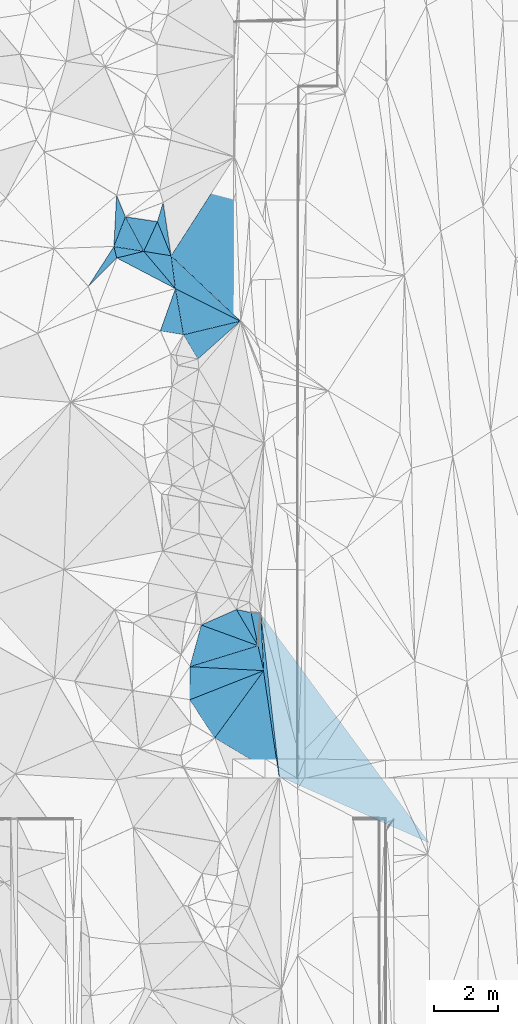
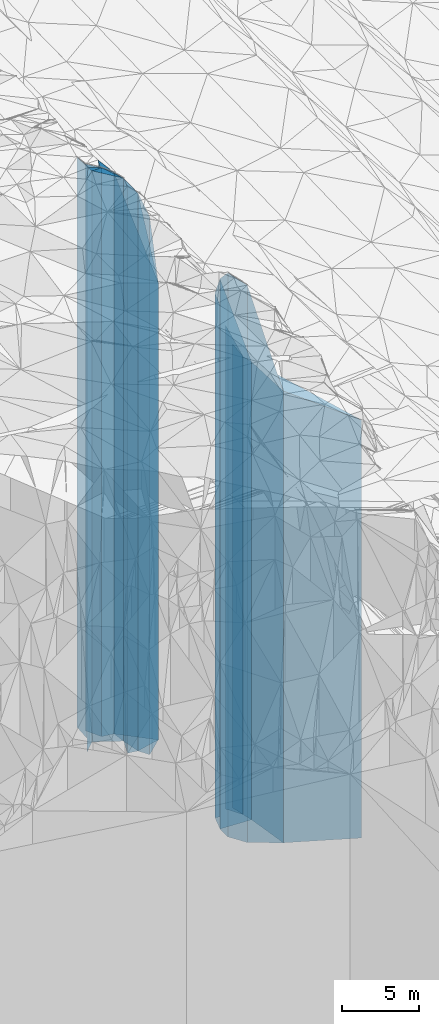
# One storey, part 250 of 275: 25 plates.
"""IFC2X3 building model written with IfcOpenShell, lengths in millimetres."""

from ifc_helpers import new_model, si_unit, frame, origin_with_axes, place, context, subcontext, project, spatial, faceted_brep, material, type_object, element, save


model = new_model("IFC2X3")

# Units and contexts
model_context = context("Model", 3, precision=1e-05, world=origin_with_axes())
body_context = subcontext(model_context, "Body", "Model", "MODEL_VIEW")
ifc_project = project(units=[si_unit("LENGTHUNIT", "METRE", prefix="MILLI"), si_unit("AREAUNIT", "SQUARE_METRE"), si_unit("VOLUMEUNIT", "CUBIC_METRE"), si_unit("MASSUNIT", "GRAM", prefix="KILO"), si_unit("TIMEUNIT", "SECOND"), si_unit("PLANEANGLEUNIT", "RADIAN"), si_unit("SOLIDANGLEUNIT", "STERADIAN"), si_unit("THERMODYNAMICTEMPERATUREUNIT", "DEGREE_CELSIUS"), si_unit("LUMINOUSINTENSITYUNIT", "LUMEN")], contexts=[model_context])

# Site, building, storey
site_placement = place(None, origin_with_axes())
site = spatial("IfcSite", under=ifc_project, at=site_placement, CompositionType="ELEMENT")
building_placement = place(site_placement, origin_with_axes())
building = spatial("IfcBuilding", under=site, at=building_placement, Name="Undefined", CompositionType="ELEMENT")
storey_placement = place(building_placement, origin_with_axes())
storey = spatial("IfcBuildingStorey", under=building, at=storey_placement, Name="Undefined", CompositionType="ELEMENT", Elevation=0.0)

# Plates
ifc_material = material()
plate_type_1 = type_object("IfcPlateType", PredefinedType="NOTDEFINED")
plate_1_placement = place(storey_placement, frame((-98025.9902817221, 87149.6399205856, 24399.5), z_axis=(0.993619641159463, 0.112783016018102, 0.0), x_axis=(0.1127830160181, -0.993619641159464, 0.0)))
element("IfcPlate", 1, at=plate_1_placement, inside=storey, type_object=plate_type_1, material=ifc_material, Name="00", context=body_context, shape_type="Brep", body=[
    faceted_brep([(0.0, -19435.4938964844, 1.09139364212751e-11), (7664.63574218751, -16571.5, 4398.71533203125), (7664.63574218751, 16571.5, 4398.71533203125), (0.0, 16571.5, -1.45519152283669e-11), (5089.28759765624, -19242.4938964844, -2.58587533608079e-08), (5089.28759765624, 16571.5, -2.58587533608079e-08)], [[[0, 1, 2, 3]], [[1, 4, 5, 2]], [[4, 0, 3, 5]], [[5, 3, 2]], [[4, 1, 0]]]),
])
plate_type_2 = type_object("IfcPlateType", PredefinedType="NOTDEFINED")
plate_2_placement = place(storey_placement, frame((-99455.0462103088, 83284.5981157701, 25979.0), z_axis=(-0.808835813129093, 0.588034546093849, 0.0), x_axis=(0.58803454609385, 0.808835813129092, 0.0)))
element("IfcPlate", 2, at=plate_2_placement, inside=storey, type_object=plate_type_2, material=ifc_material, Name="00", context=body_context, shape_type="Brep", body=[
    faceted_brep([(1.81898940354586e-12, -26031.0, 0.0), (503.80255126954, -26561.0, 1326.30419921874), (503.80255126954, 18151.0, 1326.30419921874), (1.81898940354586e-12, 18151.0, 0.0), (2589.90356445314, -18151.0, 9.29867383092642e-09), (2589.90356445314, 18151.0, 9.29867383092642e-09)], [[[0, 1, 2, 3]], [[1, 4, 5, 2]], [[4, 0, 3, 5]], [[5, 3, 2]], [[4, 1, 0]]]),
])
plate_type_3 = type_object("IfcPlateType", PredefinedType="NOTDEFINED")
plate_3_placement = place(storey_placement, frame((-97932.0934962247, 85379.4047967466, 25979.0), z_axis=(-0.053140453992429, -0.998587047857861, 0.0), x_axis=(-0.998587047857861, 0.0531404539924359, 0.0)))
element("IfcPlate", 3, at=plate_3_placement, inside=storey, type_object=plate_type_3, material=ifc_material, Name="00", context=body_context, shape_type="Brep", body=[
    faceted_brep([(0.0, -18151.0, -1.45519152283669e-11), (2247.99316406251, -26561.0, 1028.31274414061), (2247.99316406251, 18151.0, 1028.31274414061), (1.81898940354586e-12, 18151.0, 0.0), (2298.71704101564, -25471.0, -4.72937244921923e-09), (2298.71704101564, 18151.0, -4.72937244921923e-09)], [[[0, 1, 2, 3]], [[1, 4, 5, 2]], [[4, 0, 3, 5]], [[5, 3, 2]], [[4, 1, 0]]]),
])
plate_type_4 = type_object("IfcPlateType", PredefinedType="NOTDEFINED")
plate_4_placement = place(storey_placement, frame((-97932.0934962247, 85379.4047967466, 25831.5), z_axis=(-0.998596235263294, -0.0529675270139661, 0.0), x_axis=(-0.0529675270139622, 0.998596235263295, 0.0)))
element("IfcPlate", 4, at=plate_4_placement, inside=storey, type_object=plate_type_4, material=ifc_material, Name="00", context=body_context, shape_type="Brep", body=[
    faceted_brep([(0.0, -18298.5, 1.45519152283669e-11), (782.389282226563, -18318.5, 136.992584228516), (782.389282226563, 18003.5, 136.992584228516), (0.0, 18003.5, 1.45519152283669e-11), (1772.7236328125, -18003.5, 4.51109372079372e-10), (1772.7236328125, 18003.5, 4.51109372079372e-10)], [[[0, 1, 2, 3]], [[1, 4, 5, 2]], [[4, 0, 3, 5]], [[5, 3, 2]], [[4, 1, 0]]]),
])
plate_type_5 = type_object("IfcPlateType", PredefinedType="NOTDEFINED")
plate_5_placement = place(storey_placement, frame((-99455.0462103088, 83284.5981157701, 25735.0), z_axis=(0.511321646953997, 0.859389418922674, 0.0), x_axis=(0.859389418922677, -0.511321646953993, 0.0)))
element("IfcPlate", 5, at=plate_5_placement, inside=storey, type_object=plate_type_5, material=ifc_material, Name="00", context=body_context, shape_type="Brep", body=[
    faceted_brep([(2.91038304567337e-11, -26275.0, 7.27595761418343e-12), (237.689437866211, -18395.0, 2578.97338867188), (237.689437866211, 17907.0, 2578.97338867188), (7.27595761418343e-12, 17907.0, 1.45519152283669e-11), (2330.77246093753, -17907.0, -7.38509697839618e-09), (2330.77246093753, 17907.0, -7.38509697839618e-09)], [[[0, 1, 2, 3]], [[1, 4, 5, 2]], [[4, 0, 3, 5]], [[5, 3, 2]], [[4, 1, 0]]]),
])
plate_type_6 = type_object("IfcPlateType", PredefinedType="NOTDEFINED")
plate_6_placement = place(storey_placement, frame((-98782.3835816159, 87277.6952831278, 25989.0), z_axis=(0.404396271985505, -0.914583869967225, 0.0), x_axis=(-0.914583869967225, -0.404396271985505, 0.0)))
element("IfcPlate", 6, at=plate_6_placement, inside=storey, type_object=plate_type_6, material=ifc_material, Name="00", context=body_context, shape_type="Brep", body=[
    faceted_brep([(0.0, -20191.0, -1.45519152283669e-11), (-160.000000000022, -18161.0, 1299.99999999999), (-160.000000000022, 18161.0, 1299.99999999999), (0.0, 18161.0, -1.45519152283669e-11), (1189.99999999999, -23411.0, -6.97036739438772e-09), (1189.99999999999, 18161.0, -6.97036739438772e-09)], [[[0, 1, 2, 3]], [[1, 4, 5, 2]], [[4, 0, 3, 5]], [[5, 3, 2]], [[4, 1, 0]]]),
])
plate_type_7 = type_object("IfcPlateType", PredefinedType="NOTDEFINED")
plate_7_placement = place(storey_placement, frame((-100227.562552584, 85501.5596627793, 25979.0), z_axis=(0.053140453992429, 0.998587047857861, 0.0), x_axis=(0.998587047857861, -0.0531404539924359, 0.0)))
element("IfcPlate", 7, at=plate_7_placement, inside=storey, type_object=plate_type_7, material=ifc_material, Name="00", context=body_context, shape_type="Brep", body=[
    faceted_brep([(-1.45519152283669e-11, -25471.0, 0.0), (2079.5947265625, -18171.0, 763.469360351563), (2079.5947265625, 18151.0, 763.469360351563), (1.81898940354586e-12, 18151.0, 0.0), (2298.71704101563, -18151.0, -4.72937244921923e-09), (2298.71704101564, 18151.0, -4.72937244921923e-09)], [[[0, 1, 2, 3]], [[1, 4, 5, 2]], [[4, 0, 3, 5]], [[5, 3, 2]], [[4, 1, 0]]]),
])
plate_type_8 = type_object("IfcPlateType", PredefinedType="NOTDEFINED")
plate_8_placement = place(storey_placement, frame((-100227.562552584, 85501.5596627793, 25989.0), z_axis=(-0.294261248949987, 0.955725021837554, 0.0), x_axis=(0.955725021837555, 0.294261248949986, 0.0)))
element("IfcPlate", 8, at=plate_8_placement, inside=storey, type_object=plate_type_8, material=ifc_material, Name="00", context=body_context, shape_type="Brep", body=[
    faceted_brep([(1.45519152283669e-11, -25461.0, 0.0), (722.065856933608, -23411.0, 1132.57263183592), (722.065856933608, 18161.0, 1132.57263183592), (0.0, 18161.0, -1.45519152283669e-11), (2215.31030273438, -18161.0, 1.03755155578256e-08), (2215.31030273438, 18161.0, 1.03755155578256e-08)], [[[0, 1, 2, 3]], [[1, 4, 5, 2]], [[4, 0, 3, 5]], [[5, 3, 2]], [[4, 1, 0]]]),
])
plate_type_9 = type_object("IfcPlateType", PredefinedType="NOTDEFINED")
plate_9_placement = place(storey_placement, frame((-98110.3350082704, 86153.4396560286, 25989.0), z_axis=(-0.97887974518727, -0.20443689603911, 0.0), x_axis=(-0.204436896039115, 0.978879745187269, 0.0)))
element("IfcPlate", 9, at=plate_9_placement, inside=storey, type_object=plate_type_9, material=ifc_material, Name="00", context=body_context, shape_type="Brep", body=[
    faceted_brep([(2.18278728425503e-11, -18161.0, 0.0), (1237.90258789064, -20191.0, 428.015411376953), (1237.90258789064, 18161.0, 428.015411376953), (0.0, 18161.0, -1.45519152283669e-11), (1053.23315429688, -18631.0, 4.86033968627453e-09), (1053.23315429688, 18161.0, 4.86033968627453e-09)], [[[0, 1, 2, 3]], [[1, 4, 5, 2]], [[4, 0, 3, 5]], [[5, 3, 2]], [[4, 1, 0]]]),
])
plate_type_10 = type_object("IfcPlateType", PredefinedType="NOTDEFINED")
plate_10_placement = place(storey_placement, frame((-98110.3350082704, 86153.4396560286, 25869.0), z_axis=(-0.997547337593384, 0.0699950659714718, 0.0), x_axis=(0.0699950659714703, 0.997547337593384, 0.0)))
element("IfcPlate", 10, at=plate_10_placement, inside=storey, type_object=plate_type_10, material=ifc_material, Name="00", context=body_context, shape_type="Brep", body=[
    faceted_brep([(0.0, -18281.0, 1.45519152283669e-11), (1013.38861083984, -18751.0, 286.955718994155), (1013.38861083984, 18041.0, 286.955718994155), (0.0, 18041.0, 1.45519152283669e-11), (984.123962402344, -18041.0, -6.73753675073385e-09), (984.123962402344, 18041.0, -6.73753675073385e-09)], [[[0, 1, 2, 3]], [[1, 4, 5, 2]], [[4, 0, 3, 5]], [[5, 3, 2]], [[4, 1, 0]]]),
])
plate_type_11 = type_object("IfcPlateType", PredefinedType="NOTDEFINED")
plate_11_placement = place(storey_placement, frame((-97932.0934962247, 85379.4047967466, 25735.0), z_axis=(0.989498759301126, 0.144541362043991, 0.0), x_axis=(0.144541362043989, -0.989498759301126, 0.0)))
element("IfcPlate", 11, at=plate_11_placement, inside=storey, type_object=plate_type_11, material=ifc_material, Name="00", context=body_context, shape_type="Brep", body=[
    faceted_brep([(0.0, -18395.0, -1.45519152283669e-11), (-1765.21740722656, -18100.0, 162.961441040025), (-1765.21740722656, 17907.0, 162.961441040025), (7.27595761418343e-12, 17907.0, 1.45519152283669e-11), (3321.46044921875, -17907.0, 1.7054844647646e-08), (3321.46044921875, 17907.0, 1.7054844647646e-08)], [[[0, 1, 2, 3]], [[1, 4, 5, 2]], [[4, 0, 3, 5]], [[5, 3, 2]], [[4, 1, 0]]]),
])
plate_type_12 = type_object("IfcPlateType", PredefinedType="NOTDEFINED")
plate_12_placement = place(storey_placement, frame((-99980.8983192143, 95057.5450518418, 25960.0), z_axis=(-0.66450984016583, 0.747279514186481, 0.0), x_axis=(0.747279514186484, 0.664509840165827, 0.0)))
element("IfcPlate", 12, at=plate_12_placement, inside=storey, type_object=plate_type_12, material=ifc_material, Name="00", context=body_context, shape_type="Brep", body=[
    faceted_brep([(9.09494701772928e-12, -24530.0, 0.0), (170.613540649423, -26090.0, 858.947631835938), (170.613540649423, 18132.0, 858.947631835938), (-9.09494701772928e-12, 18132.0, 0.0), (1773.83337402343, -18132.0, 4.59840521216393e-09), (1773.83337402343, 18132.0, 4.59840521216393e-09)], [[[0, 1, 2, 3]], [[1, 4, 5, 2]], [[4, 0, 3, 5]], [[5, 3, 2]], [[4, 1, 0]]]),
])
plate_type_13 = type_object("IfcPlateType", PredefinedType="NOTDEFINED")
plate_13_placement = place(storey_placement, frame((-101143.836132756, 95931.9452130013, 29939.0), z_axis=(0.163344327026642, 0.986569121160912, 0.0), x_axis=(0.986569121160912, -0.163344327026642, 0.0)))
element("IfcPlate", 13, at=plate_13_placement, inside=storey, type_object=plate_type_13, material=ifc_material, Name="00", context=body_context, shape_type="Brep", body=[
    faceted_brep([(2.91038304567337e-11, -22811.0, -7.27595761418343e-12), (248.954055786118, -22511.0, 1371.02954101561), (248.954055786118, 22111.0, 1371.02954101561), (-3.63797880709171e-12, 22111.0, -2.91038304567337e-11), (729.451843261719, -22111.0, -3.63797880709171e-10), (729.451843261722, 22111.0, -2.18278728425503e-09)], [[[0, 1, 2, 3]], [[1, 4, 5, 2]], [[4, 0, 3, 5]], [[5, 3, 2]], [[4, 1, 0]]]),
])
plate_type_14 = type_object("IfcPlateType", PredefinedType="NOTDEFINED")
plate_14_placement = place(storey_placement, frame((-101657.96547473, 98405.2973957122, 30139.0), z_axis=(0.239301537088457, -0.970945299358878, 0.0), x_axis=(-0.970945299358879, -0.239301537088453, 0.0)))
element("IfcPlate", 14, at=plate_14_placement, inside=storey, type_object=plate_type_14, material=ifc_material, Name="00", context=body_context, shape_type="Brep", body=[
    faceted_brep([(1.45519152283669e-11, -22781.0, -1.45519152283669e-11), (-677.183532714829, -22311.0, 1363.05627441405), (-677.183532714829, 22311.0, 1363.05627441405), (-1.45519152283669e-11, 22311.0, 1.45519152283669e-11), (863.133850097671, -22951.0, -2.66300048679113e-09), (863.133850097671, 22311.0, -2.66300048679113e-09)], [[[0, 1, 2, 3]], [[1, 4, 5, 2]], [[4, 0, 3, 5]], [[5, 3, 2]], [[4, 1, 0]]]),
])
plate_type_15 = type_object("IfcPlateType", PredefinedType="NOTDEFINED")
plate_15_placement = place(storey_placement, frame((-100424.181463221, 95812.7933912902, 25960.0), z_axis=(-0.232833100023897, 0.972516708099795, 0.0), x_axis=(0.972516708099795, 0.232833100023896, 0.0)))
element("IfcPlate", 15, at=plate_15_placement, inside=storey, type_object=plate_type_15, material=ifc_material, Name="00", context=body_context, shape_type="Brep", body=[
    faceted_brep([(0.0, -26090.0, 1.45519152283669e-11), (89.986930847168, -26490.0, 1450.0008544922), (89.986930847168, 18132.0, 1450.0008544922), (-9.09494701772928e-12, 18132.0, 0.0), (1818.81970214844, -18132.0, 3.47790773957968e-09), (1818.81970214844, 18132.0, 3.47790773957968e-09)], [[[0, 1, 2, 3]], [[1, 4, 5, 2]], [[4, 0, 3, 5]], [[5, 3, 2]], [[4, 1, 0]]]),
])
plate_type_16 = type_object("IfcPlateType", PredefinedType="NOTDEFINED")
plate_16_placement = place(storey_placement, frame((-100809.39884045, 98266.6082930871, 30034.0), z_axis=(-0.928202011344301, -0.372076640138015, 0.0), x_axis=(-0.372076640138018, 0.9282020113443, 0.0)))
element("IfcPlate", 16, at=plate_16_placement, inside=storey, type_object=plate_type_16, material=ifc_material, Name="00", context=body_context, shape_type="Brep", body=[
    faceted_brep([(-1.45519152283669e-11, -22306.0, 0.0), (444.463317871079, -22886.0, 736.038269042961), (444.463317871079, 22206.0, 736.038269042961), (-1.45519152283669e-11, 22206.0, 0.0), (1140.70153808592, -22206.0, -6.03904481977224e-09), (1140.70153808592, 22206.0, -6.03904481977224e-09)], [[[0, 1, 2, 3]], [[1, 4, 5, 2]], [[4, 0, 3, 5]], [[5, 3, 2]], [[4, 1, 0]]]),
])
plate_type_17 = type_object("IfcPlateType", PredefinedType="NOTDEFINED")
plate_17_placement = place(storey_placement, frame((-100674.275852957, 97243.8953430122, 25960.0), z_axis=(0.446560074167959, 0.894753653336552, 0.0), x_axis=(0.894753653336548, -0.446560074167967, 0.0)))
element("IfcPlate", 17, at=plate_17_placement, inside=storey, type_object=plate_type_17, material=ifc_material, Name="00", context=body_context, shape_type="Brep", body=[
    faceted_brep([(2.91038304567337e-11, -26490.0, 7.27595761418343e-12), (-577.604553222627, -26380.0, 854.735595703125), (-577.604553222627, 18132.0, 854.735595703125), (-9.09494701772928e-12, 18132.0, 0.0), (2256.40527343753, -18132.0, -6.33008312433958e-09), (2256.40527343753, 18132.0, -6.33008312433958e-09)], [[[0, 1, 2, 3]], [[1, 4, 5, 2]], [[4, 0, 3, 5]], [[5, 3, 2]], [[4, 1, 0]]]),
])
plate_type_18 = type_object("IfcPlateType", PredefinedType="NOTDEFINED")
plate_18_placement = place(storey_placement, frame((-102229.597512672, 99475.5482136042, 30294.0), z_axis=(0.932659802744688, -0.360757109901163, 0.0), x_axis=(-0.360757109901238, -0.932659802744659, 0.0)))
element("IfcPlate", 18, at=plate_18_placement, inside=storey, type_object=plate_type_18, material=ifc_material, Name="00", context=body_context, shape_type="Brep", body=[
    faceted_brep([(0.0, -22466.0, -5.82076609134674e-11), (791.959594726563, -22626.0, 919.238830566377), (791.959594726563, 22466.0, 919.238830566377), (-7.27595761418343e-12, 22466.0, 0.0), (989.949523925781, -22866.0, -1.33877620100975e-09), (989.949523925781, 22466.0, -1.33877620100975e-09)], [[[0, 1, 2, 3]], [[1, 4, 5, 2]], [[4, 0, 3, 5]], [[5, 3, 2]], [[4, 1, 0]]]),
])
plate_type_19 = type_object("IfcPlateType", PredefinedType="NOTDEFINED")
plate_19_placement = place(storey_placement, frame((-100674.275852957, 97243.8953430122, 30084.0), z_axis=(-0.991384507672554, -0.130983807956741, 0.0), x_axis=(-0.130983807956737, 0.991384507672554, 0.0)))
element("IfcPlate", 19, at=plate_19_placement, inside=storey, type_object=plate_type_19, material=ifc_material, Name="00", context=body_context, shape_type="Brep", body=[
    faceted_brep([(1.45519152283669e-11, -22366.0, 0.0), (1280.24340820315, -22836.0, 823.089782714844), (1280.24340820315, 22256.0, 823.089782714844), (1.45519152283669e-11, 22256.0, 0.0), (1031.60070800783, -22256.0, 5.29689714312553e-09), (1031.60070800783, 22256.0, 5.29689714312553e-09)], [[[0, 1, 2, 3]], [[1, 4, 5, 2]], [[4, 0, 3, 5]], [[5, 3, 2]], [[4, 1, 0]]]),
])
plate_type_20 = type_object("IfcPlateType", PredefinedType="NOTDEFINED")
plate_20_placement = place(storey_placement, frame((-101657.96547473, 98405.2973957122, 30034.0), z_axis=(-0.908157947211607, 0.418627690097537, 0.0), x_axis=(0.418627690097539, 0.908157947211606, 0.0)))
element("IfcPlate", 20, at=plate_20_placement, inside=storey, type_object=plate_type_20, material=ifc_material, Name="00", context=body_context, shape_type="Brep", body=[
    faceted_brep([(2.91038304567337e-11, -22886.0, 0.0), (732.655761718757, -22726.0, 967.168823242217), (732.655761718757, 22206.0, 967.168823242217), (-1.45519152283669e-11, 22206.0, 0.0), (1013.16339111327, -22206.0, 5.6170392781496e-09), (1013.16339111327, 22206.0, 5.6170392781496e-09)], [[[0, 1, 2, 3]], [[1, 4, 5, 2]], [[4, 0, 3, 5]], [[5, 3, 2]], [[4, 1, 0]]]),
])
plate_type_21 = type_object("IfcPlateType", PredefinedType="NOTDEFINED")
plate_21_placement = place(storey_placement, frame((-101058.059936398, 99917.0226832819, 30034.0), z_axis=(0.958588399829156, -0.284795153949251, 0.0), x_axis=(-0.284795153949246, -0.958588399829158, 0.0)))
element("IfcPlate", 21, at=plate_21_placement, inside=storey, type_object=plate_type_21, material=ifc_material, Name="00", context=body_context, shape_type="Brep", body=[
    faceted_brep([(0.0, -22376.0, -1.45519152283669e-11), (1511.25061035157, -22306.0, 708.393676757813), (1511.25061035157, 22206.0, 708.393676757813), (-1.45519152283669e-11, 22206.0, 0.0), (617.170959472671, -22206.0, -2.4156179279089e-09), (617.170959472671, 22206.0, -2.40106601268053e-09)], [[[0, 1, 2, 3]], [[1, 4, 5, 2]], [[4, 0, 3, 5]], [[5, 3, 2]], [[4, 1, 0]]]),
])
plate_type_22 = type_object("IfcPlateType", PredefinedType="NOTDEFINED")
plate_22_placement = place(storey_placement, frame((-102586.728830791, 98552.2621140564, 30294.0), z_axis=(-0.932659802744667, 0.360757109901216, 0.0), x_axis=(0.360757109901238, 0.932659802744659, 0.0)))
element("IfcPlate", 22, at=plate_22_placement, inside=storey, type_object=plate_type_22, material=ifc_material, Name="00", context=body_context, shape_type="Brep", body=[
    faceted_brep([(-1.45519152283669e-11, -22866.0, -1.45519152283669e-11), (1513.20849609376, -22706.0, 494.97476196292), (1513.20849609376, 22466.0, 494.97476196292), (-7.27595761418343e-12, 22466.0, 0.0), (989.949523925781, -22466.0, -1.28056854009628e-09), (989.949523925781, 22466.0, -1.33877620100975e-09)], [[[0, 1, 2, 3]], [[1, 4, 5, 2]], [[4, 0, 3, 5]], [[5, 3, 2]], [[4, 1, 0]]]),
])
plate_type_23 = type_object("IfcPlateType", PredefinedType="NOTDEFINED")
plate_23_placement = place(storey_placement, frame((-101657.96547473, 98405.2973957122, 30374.0), z_axis=(-0.156292389937683, -0.987710832606167, 0.0), x_axis=(-0.987710832606167, 0.156292389937685, 0.0)))
element("IfcPlate", 23, at=plate_23_placement, inside=storey, type_object=plate_type_23, material=ifc_material, Name="00", context=body_context, shape_type="Brep", body=[
    faceted_brep([(-7.27595761418343e-12, -22546.0, -2.91038304567337e-11), (795.474670410171, -22716.0, 334.99267578125), (795.474670410171, 22546.0, 334.99267578125), (0.0, 22546.0, 0.0), (940.319091796875, -22786.0, 4.918547347188e-09), (940.319091796875, 22546.0, 4.918547347188e-09)], [[[0, 1, 2, 3]], [[1, 4, 5, 2]], [[4, 0, 3, 5]], [[5, 3, 2]], [[4, 1, 0]]]),
])
plate_type_24 = type_object("IfcPlateType", PredefinedType="NOTDEFINED")
plate_24_placement = place(storey_placement, frame((-103384.106009916, 97314.0417644368, 30459.0), z_axis=(-0.705757959680974, 0.708453034679751, 0.0), x_axis=(0.708453034679754, 0.705757959680972, 0.0)))
element("IfcPlate", 24, at=plate_24_placement, inside=storey, type_object=plate_type_24, material=ifc_material, Name="00", context=body_context, shape_type="Brep", body=[
    faceted_brep([(2.91038304567337e-11, -22811.0, -7.27595761418343e-12), (1438.78820800782, -22701.0, 314.465667724609), (1438.78820800782, 22631.0, 314.465667724609), (2.18278728425503e-11, 22631.0, 0.0), (1253.55493164063, -22631.0, 6.63567334413528e-09), (1253.55493164063, 22631.0, 6.57746568322182e-09)], [[[0, 1, 2, 3]], [[1, 4, 5, 2]], [[4, 0, 3, 5]], [[5, 3, 2]], [[4, 1, 0]]]),
])
plate_type_25 = type_object("IfcPlateType", PredefinedType="NOTDEFINED")
plate_25_placement = place(storey_placement, frame((-100809.39884045, 98266.6082930871, 25960.0), z_axis=(0.685900574862983, 0.727695266854629, 0.0), x_axis=(0.727695266854632, -0.68590057486298, 0.0)))
element("IfcPlate", 25, at=plate_25_placement, inside=storey, type_object=plate_type_25, material=ifc_material, Name="00", context=body_context, shape_type="Brep", body=[
    faceted_brep([(2.91038304567337e-11, -26380.0, 5.00222085975111e-12), (-670.39453125, -18223.0, 3578.83569335938), (-670.39453125, 18132.0, 3578.83569335938), (-9.09494701772928e-12, 18132.0, 0.0), (2960.09887695315, -18132.0, -5.9162630350329e-10), (2960.09887695315, 18132.0, -5.9162630350329e-10)], [[[0, 1, 2, 3]], [[1, 4, 5, 2]], [[4, 0, 3, 5]], [[5, 3, 2]], [[4, 1, 0]]]),
])

save(model, "model.ifc")
